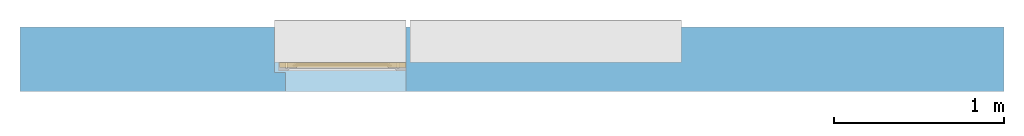
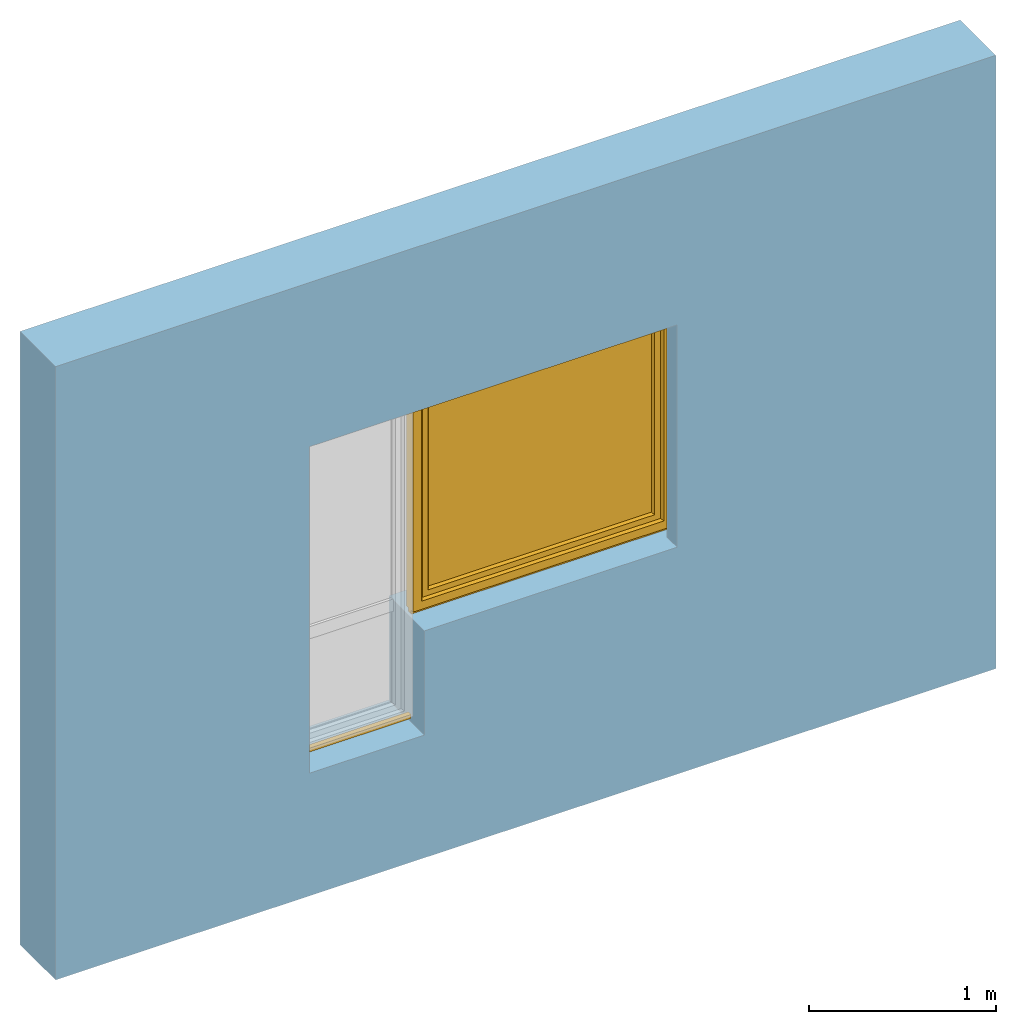
# One storey, part 2 of 4: 1 window, 1 opening, plus 1 element that does not belong to this part.
"""IFC2X3 building model written with IfcOpenShell, lengths in millimetres."""

from ifc_helpers import new_model, entity, si_unit, converted_unit, derived_unit, direction, frame, frame_2d, origin, place, context, subcontext, project, spatial, rectangle, extrude, faceted_brep, source, transform, mapped, material, material_list, layer, layer_set, layer_usage, type_object, type_shapes, element, fill, save


model = new_model("IFC2X3")

# Units and contexts
model_context = context("Model", 3, precision=0.01, world=origin(), true_north=direction((6.12303176911189e-17, 1.0)))
context_of_model = context(None, 3, precision=0.01, world=origin(), true_north=direction((6.12303176911189e-17, 1.0)))
body_context = subcontext(model_context, "Body", "Model", "MODEL_VIEW")
ifc_project = project(units=[si_unit("LENGTHUNIT", "METRE", prefix="MILLI"), si_unit("AREAUNIT", "SQUARE_METRE"), si_unit("VOLUMEUNIT", "CUBIC_METRE"), converted_unit("PLANEANGLEUNIT", "DEGREE", entity("IfcRatioMeasure", 0.0174532925199433), si_unit("PLANEANGLEUNIT", "RADIAN"), dimensions=[0, 0, 0, 0, 0, 0, 0]), si_unit("MASSUNIT", "GRAM", prefix="KILO"), si_unit("TIMEUNIT", "SECOND"), si_unit("FREQUENCYUNIT", "HERTZ"), si_unit("THERMODYNAMICTEMPERATUREUNIT", "DEGREE_CELSIUS"), derived_unit("THERMALTRANSMITTANCEUNIT", [(si_unit("MASSUNIT", "GRAM", prefix="KILO"), 1), (si_unit("THERMODYNAMICTEMPERATUREUNIT", "KELVIN"), -1), (si_unit("TIMEUNIT", "SECOND"), -3)]), derived_unit("VOLUMETRICFLOWRATEUNIT", [(si_unit("LENGTHUNIT", "METRE"), 3), (si_unit("TIMEUNIT", "SECOND"), -1)]), si_unit("ELECTRICCURRENTUNIT", "AMPERE"), si_unit("ELECTRICVOLTAGEUNIT", "VOLT"), si_unit("POWERUNIT", "WATT"), si_unit("FORCEUNIT", "NEWTON", prefix="KILO"), si_unit("ILLUMINANCEUNIT", "LUX"), si_unit("LUMINOUSFLUXUNIT", "LUMEN"), si_unit("LUMINOUSINTENSITYUNIT", "CANDELA"), si_unit("PRESSUREUNIT", "PASCAL")], contexts=[model_context, context_of_model])

# Site, building, storey
site_placement = place(None, origin())
site = spatial("IfcSite", under=ifc_project, at=site_placement, CompositionType="ELEMENT")
building_placement = place(site_placement, origin())
building = spatial("IfcBuilding", under=site, at=building_placement, CompositionType="ELEMENT")
storey_placement = place(building_placement, origin())
storey = spatial("IfcBuildingStorey", under=building, at=storey_placement, CompositionType="ELEMENT", Elevation=0.0)

# Wall, opening, window
ifc_material_1 = material()
ifc_layer = layer(ifc_material_1, 380.0)
ifc_layer_set = layer_set([ifc_layer])
ifc_layer_usage = layer_usage(ifc_layer_set, "AXIS2", "NEGATIVE", 190.0)
wall_type = type_object("IfcWallType", PredefinedType="STANDARD", material=ifc_layer_set)
wall_placement = place(storey_placement, frame((-18279.8270290102, 12543.5585138251, 0.0)))
wall = element("IfcWallStandardCase", 1, at=wall_placement, inside=storey, type_object=wall_type, material=ifc_layer_usage, context=body_context, shape_type="SweptSolid", body=[
    extrude(rectangle(XDim=5800.0, YDim=380.0, at=frame_2d((2900.0, 0.0), x_axis=(-1.0, 0.0))), origin(), (0.0, 0.0, 1.0), 4000.0),
])
opening_placement = place(wall_placement, frame((1500.0, -570.0, 800.0)))
opening = element("IfcOpeningElement", 2, at=opening_placement, cuts=wall, ObjectType="Opening", context=body_context, shape_type="Brep", body=[
    faceted_brep([(2400.0, 1490.0, 2195.0), (2400.0, 1490.0, 680.0), (775.0, 1490.0, 680.0), (775.0, 1490.0, 0.0), (0.0, 1490.0, 0.0), (0.0, 1490.0, 2195.0), (2400.0, 490.0, 2195.0), (0.0, 490.0, 2195.0), (0.0, 490.0, 0.0), (65.0, 490.0, 0.0), (65.0, 490.0, 2130.0), (2335.0, 490.0, 2130.0), (2335.0, 490.0, 680.0), (2400.0, 490.0, 680.0), (775.0, 0.0, 0.0), (65.0, 0.0, 0.0), (2335.0, 0.0, 680.0), (775.0, 0.0, 680.0), (2335.0, 0.0, 2130.0), (65.0, 0.0, 2130.0)], [[[0, 1, 2, 3, 4, 5]], [[6, 7, 8, 9, 10, 11, 12, 13]], [[5, 7, 6, 0]], [[4, 8, 7, 5]], [[3, 14, 15, 9, 8, 4]], [[0, 6, 13, 1]], [[1, 13, 12, 16, 17, 2]], [[17, 14, 3, 2]], [[18, 19, 15, 14, 17, 16]], [[18, 11, 10, 19]], [[19, 10, 9, 15]], [[16, 12, 11, 18]]]),
])
ifc_material_2 = material()
ifc_material_3 = material()
ifc_material_4 = material()
ifc_material_5 = material()
ifc_material_list_1 = material_list([ifc_material_2, ifc_material_3, ifc_material_4, ifc_material_5])
ifc_material_list_2 = material_list([ifc_material_2, ifc_material_3, ifc_material_4, ifc_material_5])
window_style = type_object("IfcWindowStyle", ConstructionType="NOTDEFINED", OperationType="NOTDEFINED", ParameterTakesPrecedence=False, Sizeable=False, material=ifc_material_list_2)
shared_shape = source(origin(), body_context, "Body", "Brep", [
    faceted_brep([(1566.0, 895.0, 1468.0), (1566.0, 895.0, 1432.0), (1566.0, 903.0, 1432.0), (1566.0, 903.0, 1468.0), (1565.15676402481, 903.0, 1472.78534851352), (1565.57778161416, 895.0, 1470.39432433822), (1560.86155337326, 895.0, 1478.56228263261), (1559.00202746122, 903.0, 1480.12318487166), (1558.998986196, 895.0, 1480.12494091649), (1543.13844662677, 903.0, 1478.56228263261), (1544.99797253881, 895.0, 1480.12318487166), (1545.00101380403, 903.0, 1480.12494091649), (1562.72637772731, 903.0, 1476.99693396948), (1562.72412055052, 895.0, 1476.99962434873), (1563.93984188941, 895.0, 1474.89413651259), (1554.43299584302, 903.0, 1481.78696961728), (1554.42953736883, 895.0, 1481.78757948929), (1556.71426178241, 895.0, 1480.95626020289), (1560.86420259427, 903.0, 1478.56005942057), (1565.1555632283, 895.0, 1472.78864867645), (1563.94157087606, 903.0, 1474.8911412415), (1556.71751165212, 903.0, 1480.95507724447), (1549.5704626312, 903.0, 1481.78757948929), (1549.56700415701, 895.0, 1481.78696961728), (1551.99827076292, 895.0, 1481.78727455329), (1547.28248834791, 895.0, 1480.95507724447), (1547.28573821762, 903.0, 1480.95626020289), (1540.05842912397, 895.0, 1474.8911412415), (1538.84443677173, 903.0, 1472.78864867645), (1538.84323597522, 895.0, 1472.78534851352), (1541.27587944951, 903.0, 1476.99962434873), (1541.27362227272, 895.0, 1476.99693396948), (1543.13579740576, 895.0, 1478.56005942057), (1552.00172923711, 903.0, 1481.78727455329), (1538.0, 895.0, 1468.0), (1538.42221838587, 903.0, 1470.39432433822), (1538.0, 903.0, 1468.0), (1540.06015811062, 903.0, 1474.89413651259), (1538.0, 895.0, 1432.0), (1538.0, 903.0, 1432.0), (1538.84323597522, 895.0, 1427.21465148645), (1538.84323597522, 903.0, 1427.21465148645), (1544.99797253881, 895.0, 1419.87681512831), (1543.13579740576, 895.0, 1421.4399405794), (1541.27362227272, 895.0, 1423.00306603049), (1541.27362227272, 903.0, 1423.00306603049), (1543.13579740576, 903.0, 1421.4399405794), (1544.99797253881, 903.0, 1419.87681512831), (1565.57778161416, 895.0, 1429.60567566175), (1565.1555632283, 895.0, 1427.21135132352), (1565.1555632283, 903.0, 1427.21135132352), (1565.56908263976, 903.0, 1429.55634534637), (1540.05842912397, 903.0, 1425.10885875847), (1540.05842912397, 895.0, 1425.10885875847), (1547.28248834791, 903.0, 1419.0449227555), (1549.56700415701, 903.0, 1418.21303038269), (1549.56700415701, 895.0, 1418.21303038269), (1547.28248834791, 895.0, 1419.0449227555), (1554.42953736882, 895.0, 1418.21242051068), (1551.99827076292, 895.0, 1418.21272544668), (1551.99827076292, 903.0, 1418.21272544668), (1554.42953736882, 903.0, 1418.21242051068), (1556.71426178241, 903.0, 1419.04373979708), (1558.998986196, 903.0, 1419.87505908348), (1558.998986196, 895.0, 1419.87505908348), (1556.71426178241, 895.0, 1419.04373979708), (1560.86155337326, 903.0, 1421.43771736736), (1562.72412055052, 903.0, 1423.00037565124), (1562.72412055052, 895.0, 1423.00037565124), (1560.86155337326, 895.0, 1421.43771736736), (1563.93984188941, 903.0, 1425.10586348738), (1563.93984188941, 895.0, 1425.10586348738), (1542.63603896934, 893.0, 1474.36396103068), (1541.7573593129, 893.0, 1472.24264068712), (1540.87867965646, 893.0, 1470.12132034356), (1540.0, 893.0, 1468.0), (1540.0, 893.0, 1432.0), (1540.87867965646, 893.0, 1429.87867965641), (1541.7573593129, 893.0, 1427.75735931285), (1542.63603896934, 893.0, 1425.63603896929), (1543.51471862578, 893.0, 1423.51471862573), (1545.63603896934, 893.0, 1422.63603896929), (1547.7573593129, 893.0, 1421.75735931285), (1549.87867965646, 893.0, 1420.87867965641), (1552.0, 893.0, 1420.0), (1554.12132034357, 893.0, 1420.87867965641), (1556.24264068713, 893.0, 1421.75735931285), (1558.36396103069, 893.0, 1422.63603896929), (1560.48528137425, 893.0, 1423.51471862573), (1561.36396103069, 893.0, 1425.63603896929), (1562.24264068713, 893.0, 1427.75735931285), (1563.12132034357, 893.0, 1429.87867965641), (1564.0, 893.0, 1432.0), (1564.0, 893.0, 1468.0), (1563.12132034357, 893.0, 1470.12132034356), (1562.24264068713, 893.0, 1472.24264068712), (1561.36396103069, 893.0, 1474.36396103068), (1560.48528137425, 893.0, 1476.48528137424), (1558.36396103069, 893.0, 1477.36396103068), (1556.24264068713, 893.0, 1478.24264068712), (1554.12132034357, 893.0, 1479.12132034356), (1552.0, 893.0, 1480.0), (1549.87867965646, 893.0, 1479.12132034356), (1547.7573593129, 893.0, 1478.24264068712), (1545.63603896934, 893.0, 1477.36396103068), (1543.51471862578, 893.0, 1476.48528137424), (1540.0, 905.0, 1468.0), (1540.87867965646, 905.0, 1470.12132034356), (1541.7573593129, 905.0, 1472.24264068712), (1542.63603896934, 905.0, 1474.36396103068), (1543.51471862578, 905.0, 1476.48528137424), (1545.63603896934, 905.0, 1477.36396103068), (1547.7573593129, 905.0, 1478.24264068712), (1549.87867965646, 905.0, 1479.12132034356), (1552.0, 905.0, 1480.0), (1554.12132034357, 905.0, 1479.12132034356), (1556.24264068713, 905.0, 1478.24264068712), (1558.36396103069, 905.0, 1477.36396103068), (1560.48528137425, 905.0, 1476.48528137424), (1561.36396103069, 905.0, 1474.36396103068), (1562.24264068713, 905.0, 1472.24264068712), (1563.12132034357, 905.0, 1470.12132034356), (1564.0, 905.0, 1468.0), (1564.0, 905.0, 1432.0), (1563.12132034357, 905.0, 1429.87867965641), (1562.24264068713, 905.0, 1427.75735931285), (1561.36396103069, 905.0, 1425.63603896929), (1560.48528137425, 905.0, 1423.51471862573), (1558.36396103069, 905.0, 1422.63603896929), (1556.24264068713, 905.0, 1421.75735931285), (1554.12132034357, 905.0, 1420.87867965641), (1552.0, 905.0, 1420.0), (1549.87867965646, 905.0, 1420.87867965641), (1547.7573593129, 905.0, 1421.75735931285), (1545.63603896934, 905.0, 1422.63603896929), (1543.51471862578, 905.0, 1423.51471862573), (1542.63603896934, 905.0, 1425.63603896929), (1541.7573593129, 905.0, 1427.75735931285), (1540.87867965646, 905.0, 1429.87867965641), (1540.0, 905.0, 1432.0)], [[[0, 1, 2, 3]], [[4, 5, 3]], [[6, 7, 8]], [[9, 10, 11]], [[12, 13, 14]], [[15, 16, 17]], [[7, 6, 18]], [[5, 0, 3]], [[18, 6, 13]], [[14, 19, 20]], [[4, 19, 5]], [[15, 17, 21]], [[8, 21, 17]], [[12, 14, 20]], [[22, 23, 24]], [[25, 11, 10]], [[26, 23, 22]], [[27, 28, 29]], [[21, 8, 7]], [[20, 19, 4]], [[30, 31, 32]], [[33, 16, 15]], [[34, 35, 36]], [[11, 25, 26]], [[23, 26, 25]], [[37, 27, 31]], [[32, 10, 9]], [[29, 28, 35]], [[30, 32, 9]], [[34, 29, 35]], [[28, 27, 37]], [[18, 13, 12]], [[33, 24, 16]], [[37, 31, 30]], [[22, 24, 33]], [[38, 34, 36, 39]], [[40, 38, 39, 41]], [[42, 43, 44, 45, 46, 47]], [[2, 1, 48, 49, 50, 51]], [[41, 52, 45, 44, 53, 40]], [[47, 54, 55, 56, 57, 42]], [[58, 59, 56, 55, 60, 61]], [[61, 62, 63, 64, 65, 58]], [[66, 67, 68, 69, 64, 63]], [[67, 70, 50, 49, 71, 68]], [[72, 73, 74, 75, 76, 77, 78, 79, 80, 81, 82, 83, 84, 85, 86, 87, 88, 89, 90, 91, 92, 93, 94, 95, 96, 97, 98, 99, 100, 101, 102, 103, 104, 105]], [[92, 48, 1]], [[48, 92, 91]], [[71, 49, 90]], [[44, 79, 53]], [[90, 49, 91]], [[78, 40, 53]], [[88, 68, 89]], [[88, 69, 68]], [[69, 87, 64]], [[89, 68, 71]], [[82, 57, 83]], [[91, 49, 48]], [[65, 85, 58]], [[82, 42, 57]], [[56, 84, 83]], [[65, 64, 86]], [[56, 83, 57]], [[76, 38, 77]], [[58, 84, 56, 59]], [[80, 44, 43]], [[85, 65, 86]], [[40, 77, 38]], [[82, 81, 42]], [[40, 78, 77]], [[43, 81, 80]], [[71, 90, 89]], [[87, 69, 88]], [[79, 44, 80]], [[79, 78, 53]], [[87, 86, 64]], [[85, 84, 58]], [[43, 42, 81]], [[92, 1, 0, 93]], [[72, 31, 27]], [[34, 74, 29]], [[27, 29, 73]], [[13, 96, 14]], [[74, 73, 29]], [[95, 19, 14]], [[104, 32, 105]], [[105, 32, 31]], [[32, 104, 10]], [[105, 31, 72]], [[99, 17, 100]], [[74, 34, 75]], [[25, 102, 23]], [[99, 8, 17]], [[16, 101, 100]], [[25, 10, 103]], [[16, 100, 17]], [[5, 93, 0]], [[99, 98, 8]], [[97, 13, 6]], [[93, 5, 94]], [[102, 25, 103]], [[94, 5, 19]], [[24, 23, 101, 16]], [[27, 73, 72]], [[96, 13, 97]], [[6, 98, 97]], [[96, 95, 14]], [[104, 103, 10]], [[102, 101, 23]], [[6, 8, 98]], [[94, 19, 95]], [[75, 34, 38, 76]], [[106, 107, 108, 109, 110, 111, 112, 113, 114, 115, 116, 117, 118, 119, 120, 121, 122, 123, 124, 125, 126, 127, 128, 129, 130, 131, 132, 133, 134, 135, 136, 137, 138, 139]], [[136, 45, 52]], [[39, 138, 41]], [[52, 41, 137]], [[67, 126, 70]], [[138, 137, 41]], [[125, 50, 70]], [[134, 46, 135]], [[135, 46, 45]], [[46, 134, 47]], [[135, 45, 136]], [[129, 62, 130]], [[138, 39, 139]], [[54, 132, 55]], [[129, 63, 62]], [[61, 131, 130]], [[54, 47, 133]], [[61, 130, 62]], [[51, 123, 2]], [[129, 128, 63]], [[127, 67, 66]], [[123, 51, 124]], [[132, 54, 133]], [[124, 51, 50]], [[60, 55, 131, 61]], [[52, 137, 136]], [[126, 67, 127]], [[66, 128, 127]], [[126, 125, 70]], [[134, 133, 47]], [[132, 131, 55]], [[66, 63, 128]], [[124, 50, 125]], [[122, 3, 2, 123]], [[119, 12, 20]], [[3, 121, 4]], [[20, 4, 120]], [[30, 109, 37]], [[121, 120, 4]], [[108, 28, 37]], [[117, 18, 118]], [[118, 18, 12]], [[18, 117, 7]], [[118, 12, 119]], [[112, 26, 113]], [[121, 3, 122]], [[21, 115, 15]], [[112, 11, 26]], [[22, 114, 113]], [[21, 7, 116]], [[22, 113, 26]], [[35, 106, 36]], [[112, 111, 11]], [[110, 30, 9]], [[106, 35, 107]], [[115, 21, 116]], [[107, 35, 28]], [[33, 15, 114, 22]], [[20, 120, 119]], [[109, 30, 110]], [[9, 111, 110]], [[109, 108, 37]], [[117, 116, 7]], [[115, 114, 15]], [[9, 11, 111]], [[107, 28, 108]], [[139, 39, 36, 106]]]),
    faceted_brep([(1546.7084973779, 844.723224744614, 1390.52114796614), (1557.29150262216, 844.723224744614, 1390.52114796614), (1557.29150262216, 849.162114765249, 1432.66882878316), (1546.7084973779, 849.162114765249, 1432.66882878316), (1559.48331477358, 853.55165186936, 1390.52114796614), (1559.48331477358, 857.796844327486, 1430.82965209671), (1552.0, 858.723224744615, 1390.52114796614), (1552.0, 862.854951797621, 1429.75228733738), (1544.51668522648, 853.551651869361, 1390.52114796614), (1544.51668522648, 857.796844327487, 1430.82965209671), (1546.7084973779, 849.162114765249, 1348.37346714912), (1557.29150262216, 849.162114765248, 1348.37346714912), (1559.48331477358, 857.796844327485, 1350.21264383557), (1552.0, 862.85495179762, 1351.29000859489), (1544.51668522648, 857.796844327486, 1350.21264383557)], [[[0, 1, 2, 3]], [[1, 4, 5, 2]], [[4, 6, 7, 5]], [[6, 8, 9, 7]], [[8, 0, 3, 9]], [[10, 11, 1, 0]], [[11, 12, 4, 1]], [[12, 13, 6, 4]], [[13, 14, 8, 6]], [[14, 10, 0, 8]], [[3, 2, 5, 7, 9]], [[14, 13, 12, 11, 10]]]),
    faceted_brep([(1542.05108068304, 893.0, 1450.94591729899), (1542.61169555871, 893.0, 1453.43924096905), (1543.78926206306, 893.0, 1455.70333478469), (1545.505173854, 893.0, 1457.59726390533), (1547.64110105649, 893.0, 1459.0), (1552.0, 893.0, 1459.0), (1556.35889894357, 893.0, 1459.0), (1558.49482614606, 893.0, 1457.59726390533), (1560.210737937, 893.0, 1455.70333478469), (1561.38830444135, 893.0, 1453.43924096905), (1561.94891931702, 893.0, 1450.94591729899), (1561.86909546586, 893.0, 1448.39192032137), (1561.13720137141, 893.0, 1445.94604186492), (1559.8094555119, 893.0, 1443.76141304128), (1557.97703479259, 893.0, 1441.98307257925), (1555.74800577774, 893.0, 1440.73512735944), (1553.27629940963, 893.0, 1440.08403873225), (1550.72370059043, 893.0, 1440.08403873225), (1548.25199422232, 893.0, 1440.73512735944), (1546.02296520747, 893.0, 1441.98307257925), (1544.19054448816, 893.0, 1443.76141304128), (1542.86279862865, 893.0, 1445.94604186492), (1542.1309045342, 893.0, 1448.39192032137), (1545.36991581397, 850.428800128995, 1431.81582813481), (1544.45534262369, 851.933218860173, 1430.80273507333), (1544.03032959919, 853.579532805236, 1429.69408812538), (1544.11827066874, 855.263398076609, 1428.56015367779), (1544.71198198392, 856.873838872345, 1427.4756641256), (1545.77997796971, 858.307181915704, 1426.51043425851), (1547.24487817872, 859.474223513819, 1425.72453488023), (1549.01896983584, 860.293497882217, 1425.17282599702), (1550.98499562505, 860.719017712975, 1424.88627599659), (1553.01500437501, 860.719017712975, 1424.88627599659), (1554.98103016422, 860.293497882217, 1425.17282599702), (1556.75512182135, 859.474223513819, 1425.72453488023), (1558.22002203036, 858.307181915703, 1426.51043425851), (1559.28801801615, 856.873838872345, 1427.4756641256), (1559.88172933132, 855.263398076608, 1428.56015367779), (1559.96967040087, 853.579532805236, 1429.69408812539), (1559.54465737637, 851.933218860173, 1430.80273507333), (1558.63008418609, 850.428800128995, 1431.81582813481), (1557.29150262216, 849.161332807082, 1432.66935536288), (1553.79310555174, 849.161332807082, 1432.66935536288), (1550.25080146482, 849.161332807082, 1432.66935536288), (1546.7084973779, 849.161332807083, 1432.66935536288), (1554.52949888049, 863.58367695897, 1448.53479166179), (1552.0, 866.40749625602, 1450.46960324716), (1552.02195286219, 856.069044221468, 1441.86725150296), (1557.17259060865, 853.432156174776, 1437.74862550587), (1554.75377578686, 855.997000236887, 1441.79007956708), (1549.6209249529, 862.432874221656, 1447.66721198752), (1549.76284265704, 870.821838386934, 1453.00337884313), (1547.01936527076, 860.326410429838, 1445.94792966368), (1549.1580531892, 855.07819011356, 1440.77853435747), (1550.96832520457, 879.059260831792, 1456.41174131504), (1547.33023316363, 875.432522578057, 1455.10298096758), (1554.09205911858, 883.083385469968, 1457.54270145075), (1556.9806347293, 860.326410429838, 1445.94792966368), (1556.66976683643, 875.432522578056, 1455.10298096758), (1560.3344526299, 860.924208850648, 1435.92276589621), (1560.86792617061, 873.480157500337, 1448.07942490612), (1561.45909914596, 882.759427033525, 1450.08550854291), (1555.91403231327, 864.739374449814, 1430.68801313961), (1557.61971635535, 869.555744991735, 1435.78506579303), (1545.02520991074, 866.744726380568, 1435.70424775682), (1542.98228348091, 874.898493111482, 1448.22389640405), (1545.18111717901, 877.977562709938, 1440.92399318816), (1558.84403415029, 880.58259477429, 1441.67364545899), (1560.73540740632, 866.455644046952, 1442.17506192799), (1542.69314957984, 883.88103613781, 1446.84627828435), (1549.47019846676, 885.315312440916, 1439.97313305253)], [[[0, 1, 2, 3, 4, 5, 6, 7, 8, 9, 10, 11, 12, 13, 14, 15, 16, 17, 18, 19, 20, 21, 22]], [[23, 24, 25, 26, 27, 28, 29, 30, 31, 32, 33, 34, 35, 36, 37, 38, 39, 40, 41, 42, 43, 44]], [[45, 46, 47]], [[42, 41, 48]], [[49, 45, 47]], [[50, 46, 51]], [[50, 51, 52]], [[43, 47, 53]], [[53, 50, 52]], [[54, 4, 55]], [[44, 43, 53]], [[56, 6, 5]], [[48, 49, 42]], [[42, 47, 43]], [[49, 48, 57]], [[5, 54, 56]], [[49, 57, 45]], [[42, 49, 47]], [[57, 58, 45]], [[58, 46, 45]], [[50, 47, 46]], [[44, 53, 52]], [[47, 50, 53]], [[46, 54, 51]], [[56, 46, 58]], [[4, 54, 5]], [[54, 55, 51]], [[52, 51, 55]], [[46, 56, 54]], [[6, 56, 58]], [[40, 59, 41]], [[39, 38, 59]], [[59, 40, 39]], [[36, 59, 37]], [[60, 61, 58]], [[35, 34, 62]], [[62, 59, 36]], [[59, 62, 63]], [[33, 62, 34]], [[35, 62, 36]], [[38, 37, 59]], [[9, 8, 61]], [[61, 10, 9]], [[64, 65, 66]], [[8, 7, 61]], [[58, 7, 6]], [[58, 61, 7]], [[63, 67, 68]], [[67, 13, 61]], [[52, 55, 65]], [[67, 60, 68]], [[31, 62, 32]], [[59, 68, 57]], [[13, 67, 14]], [[65, 69, 66]], [[10, 61, 11]], [[11, 61, 12]], [[69, 55, 1]], [[16, 70, 17]], [[33, 32, 62]], [[66, 67, 63]], [[69, 70, 66]], [[67, 66, 70]], [[70, 15, 67]], [[29, 64, 30]], [[27, 64, 28]], [[64, 29, 28]], [[65, 64, 52]], [[25, 24, 64]], [[57, 60, 58]], [[64, 24, 52]], [[23, 44, 52]], [[67, 61, 60]], [[23, 52, 24]], [[64, 26, 25]], [[69, 65, 55]], [[63, 64, 66]], [[69, 20, 19]], [[69, 21, 20]], [[61, 13, 12]], [[60, 57, 68]], [[70, 16, 15]], [[17, 70, 18]], [[68, 59, 63]], [[62, 64, 63]], [[19, 18, 70]], [[69, 1, 0]], [[0, 22, 69]], [[1, 55, 2]], [[30, 62, 31]], [[64, 27, 26]], [[3, 2, 55]], [[4, 3, 55]], [[19, 70, 69]], [[15, 14, 67]], [[21, 69, 22]], [[59, 57, 48, 41]], [[64, 62, 30]]]),
    faceted_brep([(1573.0, 975.0, 2118.0), (1573.0, 920.0, 2118.0), (1573.0, 920.0, 782.0), (1573.0, 975.0, 782.0), (1512.00008196448, 960.0, 2057.00008196445), (1524.0, 975.0, 2069.0), (1524.0, 975.0, 831.0), (1512.00008196448, 960.0, 842.999918035494), (1540.0, 918.0, 2085.0), (1540.0, 960.0, 2085.0), (1540.0, 960.0, 815.0), (1540.0, 918.0, 815.0), (1524.0, 906.0, 2069.0), (1512.0, 918.0, 2057.0), (1512.0, 918.0, 843.0), (1524.0, 906.0, 831.0), (1537.0, 905.0, 2082.0), (1537.0, 906.0, 2082.0), (1537.0, 906.0, 818.0), (1537.0, 905.0, 818.0), (1593.0, 907.0, 2138.0), (1591.0, 905.0, 2136.0), (1591.0, 905.0, 764.0), (1593.0, 907.0, 762.0), (1593.0, 920.0, 2138.0), (1593.0, 920.0, 762.0), (77.0, 920.0, 782.0), (77.0, 975.0, 782.0), (126.0, 975.0, 831.0), (137.999918035531, 960.0, 842.999918035493), (110.0, 960.0, 815.0), (110.0, 918.0, 815.0), (138.0, 918.0, 843.0), (126.0, 906.0, 831.0), (113.0, 906.0, 818.0), (113.0, 905.0, 818.0), (59.0, 905.0, 764.0), (57.0, 907.0, 762.0), (57.0, 920.0, 762.0), (77.0, 920.0, 2118.0), (77.0, 975.0, 2118.0), (126.0, 975.0, 2069.0), (137.999918035531, 960.0, 2057.00008196445), (110.0, 960.0, 2085.0), (110.0, 918.0, 2085.0), (138.0, 918.0, 2057.0), (126.0, 906.0, 2069.0), (113.0, 906.0, 2082.0), (113.0, 905.0, 2082.0), (59.0, 905.0, 2136.0), (57.0, 907.0, 2138.0), (57.0, 920.0, 2138.0)], [[[0, 1, 2, 3]], [[4, 5, 6, 7]], [[8, 9, 10, 11]], [[12, 13, 14, 15]], [[16, 17, 18, 19]], [[20, 21, 22, 23]], [[24, 20, 23, 25]], [[3, 2, 26, 27]], [[7, 6, 28, 29]], [[11, 10, 30, 31]], [[15, 14, 32, 33]], [[19, 18, 34, 35]], [[23, 22, 36, 37]], [[25, 23, 37, 38]], [[27, 26, 39, 40]], [[29, 28, 41, 42]], [[31, 30, 43, 44]], [[33, 32, 45, 46]], [[35, 34, 47, 48]], [[37, 36, 49, 50]], [[38, 37, 50, 51]], [[40, 39, 1, 0]], [[3, 27, 40, 0], [5, 41, 28, 6]], [[42, 41, 5, 4]], [[7, 29, 42, 4], [9, 43, 30, 10]], [[44, 43, 9, 8]], [[11, 31, 44, 8], [13, 45, 32, 14]], [[46, 45, 13, 12]], [[15, 33, 46, 12], [17, 47, 34, 18]], [[48, 47, 17, 16]], [[19, 35, 48, 16], [21, 49, 36, 22]], [[50, 49, 21, 20]], [[51, 50, 20, 24]], [[1, 39, 26, 2], [25, 38, 51, 24]]], outer=[[True], [True], [True], [True], [True], [True], [True], [True], [True], [True], [True], [True], [True], [True], [True], [True], [True], [True], [True], [True], [True], [True], [True, False], [True], [False, True], [True], [True, False], [True], [False, True], [True], [False, True], [True], [True], [False, True]]),
    faceted_brep([(122.0, 918.0, 2073.0), (122.0, 918.0, 827.0), (1528.0, 918.0, 827.0), (1528.0, 918.0, 2073.0), (122.0, 960.0, 2073.0), (1528.0, 960.0, 2073.0), (1528.0, 960.0, 827.0), (122.0, 960.0, 827.0)], [[[0, 1, 2, 3]], [[4, 5, 6, 7]], [[1, 0, 4, 7]], [[2, 1, 7, 6]], [[3, 2, 6, 5]], [[0, 3, 5, 4]]]),
    faceted_brep([(110.0, 923.0, 815.0), (110.0, 955.0, 815.0), (1540.0, 955.0, 815.0), (1540.0, 923.0, 815.0), (138.0, 928.0, 843.0), (138.0, 923.0, 843.0), (1512.0, 923.0, 843.0), (1512.0, 928.0, 843.0), (122.0, 950.0, 827.0), (122.0, 928.0, 827.0), (1528.0, 928.0, 827.0), (1528.0, 950.0, 827.0), (138.0, 955.0, 843.0), (138.0, 950.0, 843.0), (1512.0, 950.0, 843.0), (1512.0, 955.0, 843.0), (1540.0, 955.0, 2085.0), (1540.0, 923.0, 2085.0), (1512.0, 923.0, 2057.0), (1512.0, 928.0, 2057.0), (1528.0, 928.0, 2073.0), (1528.0, 950.0, 2073.0), (1512.0, 950.0, 2057.0), (1512.0, 955.0, 2057.0), (110.0, 955.0, 2085.0), (110.0, 923.0, 2085.0), (138.0, 923.0, 2057.0), (138.0, 928.0, 2057.0), (122.0, 928.0, 2073.0), (122.0, 950.0, 2073.0), (138.0, 950.0, 2057.0), (138.0, 955.0, 2057.0)], [[[0, 1, 2, 3]], [[4, 5, 6, 7]], [[8, 9, 10, 11]], [[12, 13, 14, 15]], [[3, 2, 16, 17]], [[7, 6, 18, 19]], [[11, 10, 20, 21]], [[15, 14, 22, 23]], [[17, 16, 24, 25]], [[19, 18, 26, 27]], [[21, 20, 28, 29]], [[23, 22, 30, 31]], [[15, 23, 31, 12], [1, 24, 16, 2]], [[25, 24, 1, 0]], [[3, 17, 25, 0], [5, 26, 18, 6]], [[27, 26, 5, 4]], [[7, 19, 27, 4], [9, 28, 20, 10]], [[29, 28, 9, 8]], [[11, 21, 29, 8], [13, 30, 22, 14]], [[31, 30, 13, 12]]], outer=[[True], [True], [True], [True], [True], [True], [True], [True], [True], [True], [True], [True], [False, True], [True], [True, False], [True], [False, True], [True], [True, False], [True]]),
    faceted_brep([(25.0, 990.0, 2170.0), (25.0, 920.0, 2170.0), (1625.0, 920.0, 2170.0), (1625.0, 990.0, 2170.0), (1625.0, 920.0, 730.0), (1625.0, 990.0, 730.0), (25.0, 920.0, 730.0), (1585.0, 920.0, 770.0), (65.0, 920.0, 770.0), (65.0, 920.0, 2130.0), (1585.0, 920.0, 2130.0), (1572.0, 990.0, 2117.0), (78.0, 990.0, 2117.0), (78.0, 990.0, 783.0), (1572.0, 990.0, 783.0), (25.0, 990.0, 730.0), (65.0, 975.0, 2130.0), (1585.0, 975.0, 2130.0), (1585.0, 975.0, 770.0), (65.0, 975.0, 770.0), (1560.0, 975.0, 795.0), (90.0, 975.0, 795.0), (90.0, 975.0, 2105.0), (1560.0, 975.0, 2105.0)], [[[0, 1, 2, 3]], [[3, 2, 4, 5]], [[2, 1, 6, 4], [7, 8, 9, 10]], [[11, 12, 13, 14], [5, 15, 0, 3]], [[9, 16, 17, 10]], [[10, 17, 18, 7]], [[17, 16, 19, 18], [20, 21, 22, 23]], [[15, 6, 1, 0]], [[8, 19, 16, 9]], [[22, 12, 11, 23]], [[21, 13, 12, 22]], [[23, 11, 14, 20]], [[5, 4, 6, 15]], [[7, 18, 19, 8]], [[20, 14, 13, 21]]], outer=[[True], [True], [True, False], [False, True], [True], [True], [True, False], [True], [True], [True], [True], [True], [True], [True], [True]]),
    faceted_brep([(1625.0, 970.0, 25.0), (1625.0, 970.0, 50.0), (2370.0, 970.0, 50.0), (2370.0, 970.0, 25.0), (1625.0, 940.0, 25.0), (2370.0, 940.0, 25.0), (2370.0, 940.0, 50.0), (1625.0, 940.0, 50.0)], [[[0, 1, 2, 3]], [[4, 5, 6, 7]], [[5, 4, 0, 3]], [[6, 5, 3, 2]], [[7, 6, 2, 1]], [[4, 7, 1, 0]]]),
    faceted_brep([(1625.0, 970.0, 730.0), (1625.0, 970.0, 705.0), (30.0, 970.0, 705.0), (30.0, 970.0, 730.0), (1625.0, 940.0, 730.0), (30.0, 940.0, 730.0), (30.0, 940.0, 705.0), (1625.0, 940.0, 705.0)], [[[0, 1, 2, 3]], [[4, 5, 6, 7]], [[5, 4, 0, 3]], [[6, 5, 3, 2]], [[7, 6, 2, 1]], [[4, 7, 1, 0]]]),
])
type_shapes(window_style, [shared_shape])
window_placement = place(opening_placement, frame((2400.0, 1490.0, 0.0), z_axis=(0.0, 0.0, 1.0), x_axis=(-1.0, 0.0, 0.0)))
window = element("IfcWindow", 3, at=window_placement, inside=storey, type_object=window_style, material=ifc_material_list_1, OverallHeight=2195.0, OverallWidth=2400.00000000002, context=body_context, shape_type="MappedRepresentation", body=[
    mapped(shared_shape, transform((0.0, 0.0, 0.0), scale=1.0)),
])
fill(opening, window)

save(model, "model.ifc")
